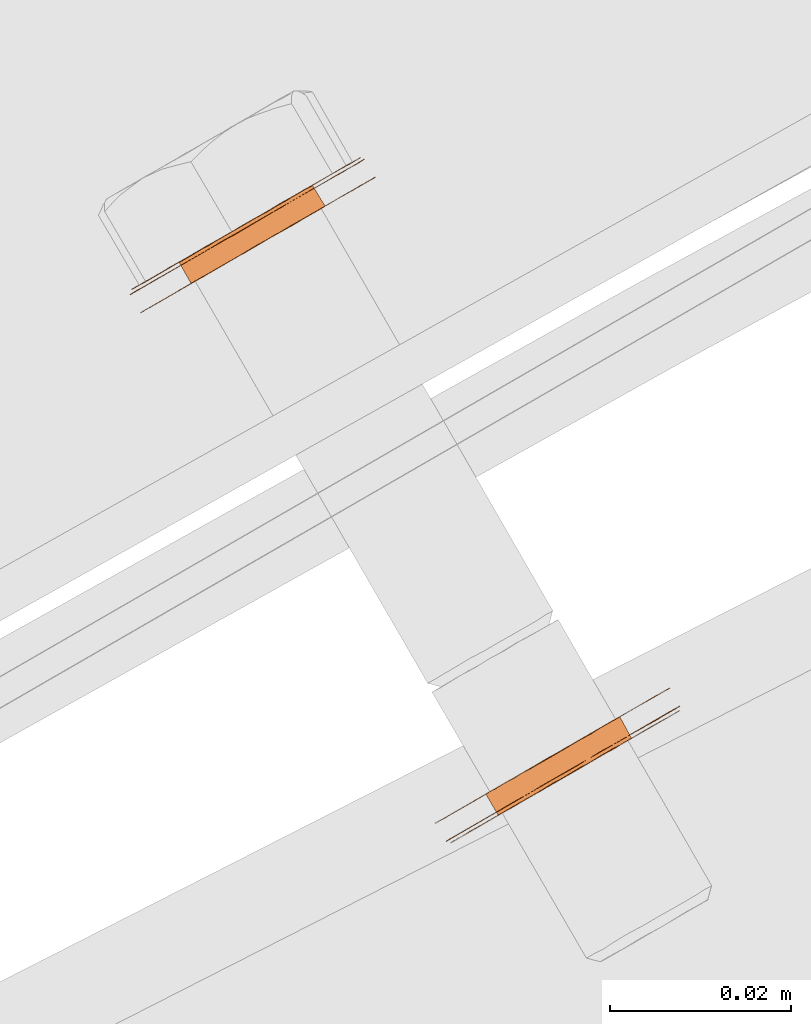
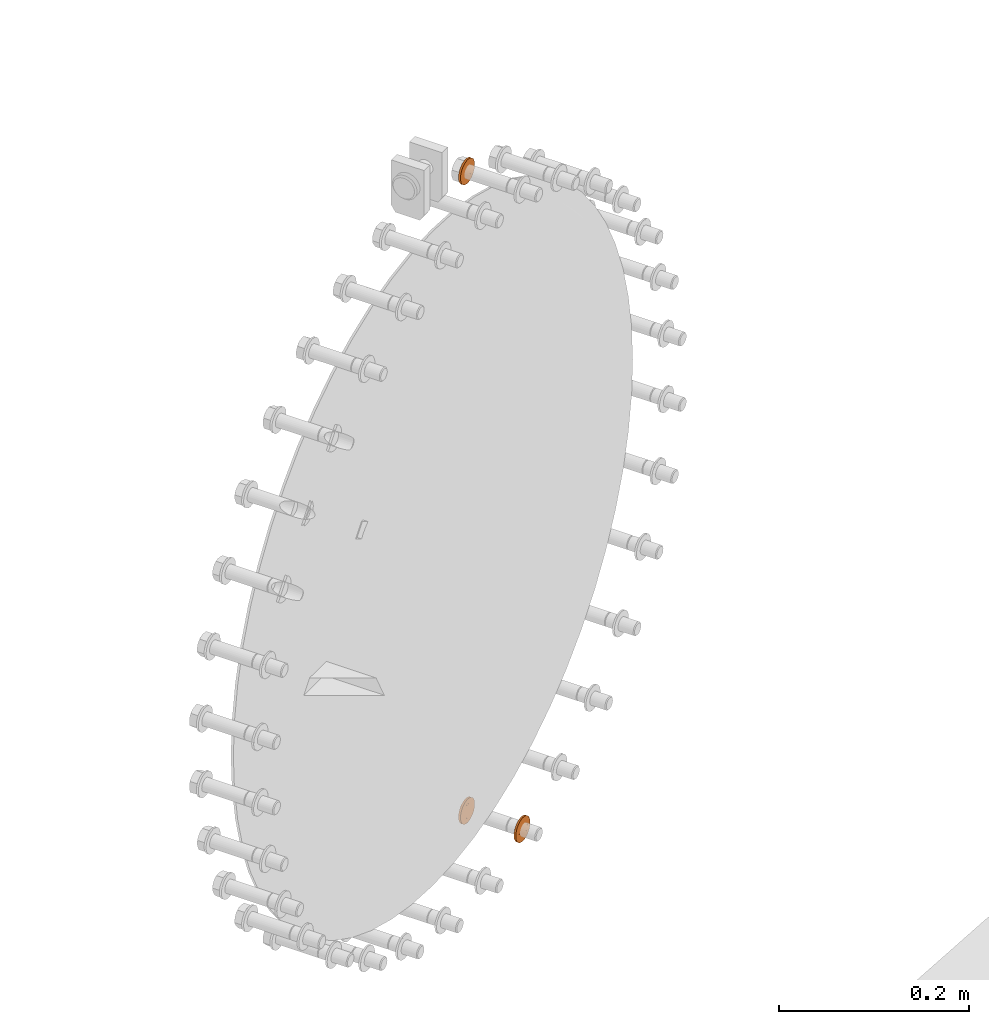
# One storey, part 111 of 126: 3 proxies.
"""IFC2X3 building model written with IfcOpenShell, lengths in millimetres."""

from ifc_helpers import new_model, si_unit, origin, origin_with_axes, place, context, project, spatial, faceted_brep, material, element, save


model = new_model("IFC2X3")

# Units and contexts
context_of_model_1 = context(None, 3, precision=0.1, world=origin())
context_of_model_2 = context(None, 3, precision=0.1, world=origin())
ifc_project = project(units=[si_unit("LENGTHUNIT", "METRE", prefix="MILLI"), si_unit("AREAUNIT", "SQUARE_METRE", prefix="CENTI"), si_unit("VOLUMEUNIT", "CUBIC_METRE", prefix="CENTI"), si_unit("MASSUNIT", "GRAM", prefix="KILO")], contexts=[context_of_model_1, context_of_model_2])

# Site, building, storey
site_placement = place(None, origin_with_axes())
site = spatial("IfcSite", under=ifc_project, at=site_placement, CompositionType="ELEMENT")
building_placement = place(site_placement, origin_with_axes())
building = spatial("IfcBuilding", under=site, at=building_placement, CompositionType="ELEMENT")
storey_placement = place(building_placement, origin_with_axes())
storey = spatial("IfcBuildingStorey", under=building, at=storey_placement, CompositionType="ELEMENT")

# Proxies
ifc_material = material(Name="STAHL")
proxy_1_placement = place(storey_placement, origin_with_axes())
element("IfcBuildingElementProxy", 1, at=proxy_1_placement, inside=storey, material=ifc_material, Name="profile", context=context_of_model_2, shape_type="Brep", body=[
    faceted_brep([(4093.0, 15031.0, 1299.0), (4094.4, 15028.7, 1299.0), (4095.4, 15029.3, 1299.1), (4094.1, 15031.6, 1299.1), (4092.0, 15030.4, 1299.0), (4093.3, 15028.1, 1299.0), (4090.9, 15029.8, 1299.2), (4092.3, 15027.5, 1299.2), (4096.5, 15033.0, 1314.8), (4097.9, 15030.7, 1314.8), (4096.9, 15030.1, 1315.3), (4095.6, 15032.5, 1315.3), (4089.9, 15029.2, 1299.6), (4091.3, 15026.9, 1299.6), (4097.4, 15033.5, 1314.1), (4098.7, 15031.2, 1314.1), (4098.1, 15034.0, 1313.3), (4099.5, 15031.6, 1313.3), (4098.8, 15034.4, 1312.3), (4100.1, 15032.0, 1312.3), (4099.3, 15034.7, 1311.3), (4100.7, 15032.3, 1311.3), (4099.7, 15034.9, 1310.2), (4101.1, 15032.6, 1310.2), (4100.0, 15035.0, 1309.0), (4101.3, 15032.7, 1309.0), (4100.1, 15035.1, 1307.8), (4101.5, 15032.8, 1307.8), (4100.1, 15035.1, 1306.6), (4101.4, 15032.7, 1306.6), (4099.9, 15035.0, 1305.4), (4101.2, 15032.6, 1305.4), (4099.6, 15034.8, 1304.2), (4100.9, 15032.4, 1304.2), (4099.1, 15034.5, 1303.1), (4100.4, 15032.2, 1303.1), (4098.5, 15034.2, 1302.2), (4099.8, 15031.8, 1302.2), (4097.8, 15033.8, 1301.3), (4099.1, 15031.4, 1301.3), (4096.9, 15033.3, 1300.5), (4098.3, 15030.9, 1300.5), (4096.0, 15032.8, 1299.9), (4097.4, 15030.4, 1299.9), (4095.1, 15032.2, 1299.4), (4096.4, 15029.9, 1299.4), (4081.1, 15021.0, 1307.1), (4081.1, 15021.0, 1308.7), (4081.3, 15021.1, 1310.2), (4081.6, 15021.3, 1311.7), (4082.1, 15021.6, 1313.2), (4082.7, 15021.9, 1314.6), (4083.4, 15022.3, 1316.0), (4084.2, 15022.8, 1317.2), (4085.2, 15023.4, 1318.4), (4086.2, 15024.0, 1319.4), (4087.3, 15024.6, 1320.3), (4088.5, 15025.3, 1321.0), (4089.8, 15026.0, 1321.6), (4091.1, 15026.8, 1322.1), (4092.4, 15027.5, 1322.4), (4093.8, 15028.3, 1322.5), (4095.1, 15029.1, 1322.4), (4096.5, 15029.9, 1322.2), (4097.8, 15030.7, 1321.9), (4099.1, 15031.4, 1321.3), (4100.3, 15032.1, 1320.7), (4101.5, 15032.8, 1319.8), (4102.5, 15033.4, 1318.9), (4103.5, 15034.0, 1317.8), (4104.4, 15034.5, 1316.6), (4105.2, 15034.9, 1315.3), (4105.8, 15035.3, 1313.9), (4106.3, 15035.6, 1312.5), (4106.7, 15035.8, 1311.0), (4107.0, 15036.0, 1309.4), (4107.1, 15036.0, 1307.9), (4107.0, 15036.0, 1306.3), (4106.9, 15035.9, 1304.8), (4106.6, 15035.7, 1303.2), (4106.1, 15035.5, 1301.7), (4105.5, 15035.1, 1300.3), (4104.8, 15034.7, 1299.0), (4104.0, 15034.2, 1297.7), (4103.0, 15033.7, 1296.6), (4102.0, 15033.1, 1295.6), (4100.9, 15035.1, 1295.6), (4101.9, 15035.7, 1296.6), (4102.8, 15036.2, 1297.7), (4103.7, 15036.7, 1299.0), (4104.4, 15037.1, 1300.3), (4105.0, 15037.4, 1301.7), (4105.4, 15037.7, 1303.2), (4105.7, 15037.9, 1304.8), (4105.9, 15038.0, 1306.3), (4105.9, 15038.0, 1307.9), (4105.8, 15038.0, 1309.4), (4105.6, 15037.8, 1311.0), (4105.2, 15037.6, 1312.5), (4104.7, 15037.3, 1313.9), (4104.0, 15036.9, 1315.3), (4103.3, 15036.5, 1316.6), (4102.4, 15036.0, 1317.8), (4101.4, 15035.4, 1318.9), (4100.3, 15034.8, 1319.8), (4099.1, 15034.1, 1320.7), (4097.9, 15033.4, 1321.3), (4096.6, 15032.6, 1321.9), (4095.3, 15031.9, 1322.2), (4094.0, 15031.1, 1322.4), (4092.6, 15030.3, 1322.5), (4091.3, 15029.5, 1322.4), (4089.9, 15028.8, 1322.1), (4088.6, 15028.0, 1321.6), (4087.4, 15027.3, 1321.0), (4086.2, 15026.6, 1320.3), (4085.0, 15025.9, 1319.4), (4084.0, 15025.4, 1318.4), (4083.1, 15024.8, 1317.2), (4082.2, 15024.3, 1316.0), (4081.5, 15023.9, 1314.6), (4080.9, 15023.6, 1313.2), (4080.5, 15023.3, 1311.7), (4080.2, 15023.1, 1310.2), (4080.0, 15023.0, 1308.7), (4080.0, 15023.0, 1307.1), (4080.1, 15023.1, 1305.5), (4080.3, 15023.2, 1304.0), (4080.7, 15023.4, 1302.5), (4081.2, 15023.7, 1301.0), (4081.9, 15024.1, 1299.6), (4082.6, 15024.6, 1298.4), (4083.5, 15025.1, 1297.2), (4084.5, 15025.6, 1296.1), (4085.6, 15026.3, 1295.1), (4086.8, 15026.9, 1294.3), (4088.0, 15027.6, 1293.6), (4089.3, 15028.4, 1293.1), (4090.6, 15029.1, 1292.7), (4091.9, 15029.9, 1292.5), (4093.3, 15030.7, 1292.5), (4094.6, 15031.5, 1292.6), (4096.0, 15032.3, 1292.9), (4097.3, 15033.0, 1293.3), (4098.5, 15033.7, 1293.9), (4099.7, 15034.4, 1294.7), (4100.9, 15032.4, 1294.7), (4099.7, 15031.8, 1293.9), (4098.4, 15031.0, 1293.3), (4097.1, 15030.3, 1292.9), (4095.8, 15029.5, 1292.6), (4094.4, 15028.7, 1292.5), (4093.1, 15027.9, 1292.5), (4091.7, 15027.2, 1292.7), (4090.4, 15026.4, 1293.1), (4089.1, 15025.7, 1293.6), (4087.9, 15024.9, 1294.3), (4086.7, 15024.3, 1295.1), (4085.7, 15023.7, 1296.1), (4084.7, 15023.1, 1297.2), (4083.8, 15022.6, 1298.4), (4083.0, 15022.1, 1299.6), (4082.4, 15021.8, 1301.0), (4081.9, 15021.5, 1302.5), (4081.5, 15021.2, 1304.0), (4081.2, 15021.1, 1305.5), (4081.2, 15024.2, 1301.5), (4081.8, 15024.6, 1300.1), (4082.6, 15025.0, 1298.8), (4083.5, 15025.5, 1297.6), (4084.4, 15026.1, 1296.5), (4085.5, 15026.7, 1295.5), (4086.7, 15027.4, 1294.7), (4087.9, 15028.1, 1294.0), (4089.2, 15028.8, 1293.5), (4090.5, 15029.6, 1293.1), (4091.9, 15030.4, 1292.9), (4093.3, 15031.2, 1292.9), (4094.6, 15031.9, 1293.0), (4096.0, 15032.7, 1293.4), (4097.3, 15033.5, 1293.8), (4098.5, 15034.2, 1294.5), (4099.7, 15034.9, 1295.3), (4100.8, 15035.5, 1296.2), (4101.8, 15036.1, 1297.3), (4102.7, 15036.6, 1298.5), (4103.5, 15037.1, 1299.8), (4104.2, 15037.4, 1301.2), (4104.7, 15037.7, 1302.6), (4105.1, 15038.0, 1304.2), (4105.3, 15038.1, 1305.7), (4105.4, 15038.2, 1307.3), (4105.3, 15038.1, 1308.9), (4105.1, 15038.0, 1310.4), (4104.8, 15037.8, 1312.0), (4104.3, 15037.5, 1313.4), (4103.7, 15037.2, 1314.8), (4102.9, 15036.7, 1316.2), (4102.0, 15036.2, 1317.4), (4101.1, 15035.7, 1318.5), (4100.0, 15035.0, 1319.5), (4098.8, 15034.4, 1320.3), (4097.6, 15033.7, 1321.0), (4096.3, 15032.9, 1321.5), (4095.0, 15032.1, 1321.9), (4093.6, 15031.4, 1322.1), (4092.2, 15030.6, 1322.1), (4090.9, 15029.8, 1321.9), (4089.5, 15029.0, 1321.6), (4088.2, 15028.3, 1321.1), (4087.0, 15027.5, 1320.5), (4085.8, 15026.8, 1319.7), (4084.7, 15026.2, 1318.7), (4083.7, 15025.6, 1317.7), (4082.8, 15025.1, 1316.5), (4082.0, 15024.7, 1315.2), (4081.3, 15024.3, 1313.8), (4080.8, 15024.0, 1312.3), (4080.4, 15023.8, 1310.8), (4080.2, 15023.6, 1309.3), (4080.1, 15023.6, 1307.7), (4080.2, 15023.6, 1306.1), (4080.4, 15023.7, 1304.5), (4080.7, 15023.9, 1303.0), (4085.8, 15026.8, 1304.8), (4086.2, 15027.1, 1303.7), (4086.7, 15027.4, 1302.6), (4087.4, 15027.8, 1301.7), (4088.1, 15028.2, 1300.9), (4089.0, 15028.7, 1300.2), (4094.6, 15031.9, 1315.7), (4093.5, 15031.3, 1315.9), (4092.5, 15030.7, 1316.0), (4091.4, 15030.1, 1315.8), (4090.4, 15029.5, 1315.5), (4089.5, 15029.0, 1315.1), (4088.6, 15028.4, 1314.5), (4087.7, 15028.0, 1313.7), (4087.0, 15027.6, 1312.8), (4086.4, 15027.2, 1311.8), (4085.9, 15026.9, 1310.7), (4085.6, 15026.7, 1309.6), (4085.4, 15026.6, 1308.4), (4085.4, 15026.6, 1307.2), (4085.5, 15026.7, 1306.0), (4095.9, 15029.6, 1315.7), (4090.3, 15026.4, 1300.2), (4089.5, 15025.9, 1300.9), (4088.7, 15025.4, 1301.7), (4088.1, 15025.0, 1302.6), (4087.5, 15024.7, 1303.7), (4087.1, 15024.5, 1304.8), (4086.9, 15024.3, 1306.0), (4086.7, 15024.3, 1307.2), (4086.8, 15024.3, 1308.4), (4087.0, 15024.4, 1309.6), (4087.3, 15024.6, 1310.7), (4087.8, 15024.9, 1311.8), (4088.4, 15025.2, 1312.8), (4089.1, 15025.6, 1313.7), (4089.9, 15026.1, 1314.5), (4090.8, 15026.6, 1315.1), (4091.8, 15027.2, 1315.5), (4092.8, 15027.8, 1315.8), (4093.8, 15028.4, 1316.0), (4094.9, 15029.0, 1315.9)], [[[0, 1, 2, 3]], [[4, 5, 1, 0]], [[6, 7, 5, 4]], [[8, 9, 10, 11]], [[12, 13, 7, 6]], [[14, 15, 9, 8]], [[16, 17, 15, 14]], [[18, 19, 17, 16]], [[20, 21, 19, 18]], [[22, 23, 21, 20]], [[24, 25, 23, 22]], [[26, 27, 25, 24]], [[28, 29, 27, 26]], [[30, 31, 29, 28]], [[32, 33, 31, 30]], [[34, 35, 33, 32]], [[36, 37, 35, 34]], [[38, 39, 37, 36]], [[40, 41, 39, 38]], [[42, 43, 41, 40]], [[44, 45, 43, 42]], [[3, 2, 45, 44]], [[46, 47, 48, 49, 50, 51, 52, 53, 54, 55, 56, 57, 58, 59, 60, 61, 62, 63, 64, 65, 66, 67, 68, 69, 70, 71, 72, 73, 74, 75, 76, 77, 78, 79, 80, 81, 82, 83, 84, 85, 86, 87, 88, 89, 90, 91, 92, 93, 94, 95, 96, 97, 98, 99, 100, 101, 102, 103, 104, 105, 106, 107, 108, 109, 110, 111, 112, 113, 114, 115, 116, 117, 118, 119, 120, 121, 122, 123, 124, 125, 126, 127, 128, 129, 130, 131, 132, 133, 134, 135, 136, 137, 138, 139, 140, 141, 142, 143, 144, 145, 86, 85, 146, 147, 148, 149, 150, 151, 152, 153, 154, 155, 156, 157, 158, 159, 160, 161, 162, 163, 164, 165]], [[125, 124, 123, 122, 121, 120, 119, 118, 117, 116, 115, 114, 113, 112, 111, 110, 109, 108, 107, 106, 105, 104, 103, 102, 101, 100, 99, 98, 97, 96, 95, 94, 93, 92, 91, 90, 89, 88, 87, 86, 145, 144, 143, 142, 141, 140, 139, 138, 137, 136, 135, 134, 133, 132, 131, 130, 129, 166, 167, 168, 169, 170, 171, 172, 173, 174, 175, 176, 177, 178, 179, 180, 181, 182, 183, 184, 185, 186, 187, 188, 189, 190, 191, 192, 193, 194, 195, 196, 197, 198, 199, 200, 201, 202, 203, 204, 205, 206, 207, 208, 209, 210, 211, 212, 213, 214, 215, 216, 217, 218, 219, 220, 221, 222, 223, 166, 129, 128, 127, 126]], [[220, 219, 218, 217, 216, 215, 214, 213, 212, 211, 210, 209, 208, 207, 206, 205, 204, 203, 202, 201, 200, 199, 198, 197, 196, 195, 194, 193, 192, 191, 190, 189, 188, 187, 186, 185, 184, 183, 182, 181, 180, 179, 178, 177, 176, 175, 174, 173, 172, 171, 170, 169, 168, 167, 166, 223, 222, 224, 225, 226, 227, 228, 229, 12, 6, 4, 0, 3, 44, 42, 40, 38, 36, 34, 32, 30, 28, 26, 24, 22, 20, 18, 16, 14, 8, 11, 230, 231, 232, 233, 234, 235, 236, 237, 238, 239, 240, 241, 242, 243, 244, 224, 222, 221]], [[230, 11, 10, 245]], [[12, 229, 246, 13]], [[229, 228, 247, 246]], [[228, 227, 248, 247]], [[227, 226, 249, 248]], [[226, 225, 250, 249]], [[225, 224, 251, 250]], [[224, 244, 252, 251]], [[244, 243, 253, 252]], [[243, 242, 254, 253]], [[242, 241, 255, 254]], [[241, 240, 256, 255]], [[240, 239, 257, 256]], [[239, 238, 258, 257]], [[238, 237, 259, 258]], [[237, 236, 260, 259]], [[236, 235, 261, 260]], [[235, 234, 262, 261]], [[234, 233, 263, 262]], [[233, 232, 264, 263]], [[232, 231, 265, 264]], [[231, 230, 245, 265]], [[46, 165, 164, 163, 251, 252, 253, 254, 255, 256, 257, 258, 259, 260, 261, 262, 263, 264, 265, 245, 10, 9, 15, 17, 19, 21, 23, 25, 27, 29, 31, 33, 35, 37, 39, 41, 43, 45, 2, 1, 5, 7, 13, 246, 247, 248, 249, 250, 251, 163, 162, 161, 160, 159, 158, 157, 156, 155, 154, 153, 152, 151, 150, 149, 148, 147, 146, 85, 84, 83, 82, 81, 80, 79, 78, 77, 76, 75, 74, 73, 72, 71, 70, 69, 68, 67, 66, 65, 64, 63, 62, 61, 60, 59, 58, 57, 56, 55, 54, 53, 52, 51, 50, 49, 48, 47]]]),
])
proxy_2_placement = place(storey_placement, origin_with_axes())
element("IfcBuildingElementProxy", 2, at=proxy_2_placement, inside=storey, material=ifc_material, Name="profile", context=context_of_model_2, shape_type="Brep", body=[
    faceted_brep([(4126.5, 14969.1, 492.9), (4125.2, 14971.4, 492.9), (4126.2, 14972.0, 493.0), (4127.6, 14969.7, 493.0), (4129.4, 14970.7, 476.2), (4130.4, 14971.3, 476.5), (4129.0, 14973.6, 476.5), (4128.0, 14973.1, 476.2), (4131.4, 14971.9, 477.0), (4130.0, 14974.2, 477.0), (4132.3, 14972.4, 477.6), (4130.9, 14974.7, 477.6), (4133.1, 14972.8, 478.4), (4131.7, 14975.2, 478.4), (4133.8, 14973.2, 479.3), (4132.4, 14975.6, 479.3), (4134.3, 14973.6, 480.3), (4133.0, 14975.9, 480.3), (4134.8, 14973.8, 481.4), (4133.4, 14976.2, 481.4), (4135.1, 14974.0, 482.6), (4133.8, 14976.4, 482.6), (4135.3, 14974.1, 483.8), (4133.9, 14976.5, 483.8), (4135.3, 14974.1, 485.0), (4134.0, 14976.5, 485.0), (4135.2, 14974.1, 486.2), (4133.8, 14976.4, 486.2), (4134.9, 14973.9, 487.3), (4133.5, 14976.2, 487.3), (4134.5, 14973.7, 488.5), (4133.1, 14976.0, 488.5), (4133.9, 14973.3, 489.5), (4132.6, 14975.7, 489.5), (4133.2, 14973.0, 490.4), (4131.9, 14975.3, 490.4), (4132.5, 14972.5, 491.2), (4131.1, 14974.8, 491.2), (4131.6, 14972.0, 491.9), (4130.2, 14974.3, 491.9), (4130.6, 14971.4, 492.4), (4129.3, 14973.8, 492.4), (4129.6, 14970.9, 492.8), (4128.3, 14973.2, 492.8), (4128.6, 14970.3, 493.0), (4127.3, 14972.6, 493.0), (4114.8, 14962.7, 484.7), (4114.8, 14962.8, 486.3), (4115.1, 14962.9, 487.8), (4115.4, 14963.1, 489.3), (4116.0, 14963.4, 490.8), (4116.6, 14963.8, 492.2), (4117.3, 14964.2, 493.5), (4118.2, 14964.7, 494.7), (4119.2, 14965.3, 495.8), (4120.3, 14965.9, 496.8), (4121.4, 14966.6, 497.6), (4122.6, 14967.3, 498.3), (4123.9, 14968.0, 498.8), (4125.2, 14968.8, 499.2), (4126.6, 14969.6, 499.5), (4127.9, 14970.3, 499.5), (4129.3, 14971.1, 499.4), (4130.6, 14971.9, 499.1), (4131.9, 14972.7, 498.7), (4133.2, 14973.4, 498.1), (4134.4, 14974.1, 497.4), (4135.5, 14974.7, 496.5), (4136.6, 14975.3, 495.5), (4137.5, 14975.9, 494.4), (4137.2, 14978.4, 493.2), (4136.4, 14977.9, 494.4), (4135.4, 14977.3, 495.5), (4134.4, 14976.7, 496.5), (4133.2, 14976.1, 497.4), (4132.0, 14975.4, 498.1), (4130.8, 14974.6, 498.7), (4129.5, 14973.9, 499.1), (4128.1, 14973.1, 499.4), (4126.8, 14972.3, 499.5), (4125.4, 14971.5, 499.5), (4124.1, 14970.8, 499.2), (4122.7, 14970.0, 498.8), (4121.5, 14969.3, 498.3), (4120.3, 14968.6, 497.6), (4119.1, 14967.9, 496.8), (4118.0, 14967.3, 495.8), (4117.1, 14966.7, 494.7), (4116.2, 14966.2, 493.5), (4115.4, 14965.8, 492.2), (4114.8, 14965.4, 490.8), (4114.3, 14965.1, 489.3), (4113.9, 14964.9, 487.8), (4113.7, 14964.8, 486.3), (4113.6, 14964.7, 484.7), (4113.7, 14964.8, 483.1), (4113.9, 14964.9, 481.6), (4114.2, 14965.1, 480.1), (4114.7, 14965.3, 478.6), (4115.3, 14965.7, 477.2), (4116.0, 14966.1, 475.9), (4116.8, 14966.6, 474.6), (4117.8, 14967.1, 473.5), (4118.8, 14967.7, 472.5), (4120.0, 14968.4, 471.6), (4121.2, 14969.1, 470.9), (4122.4, 14969.8, 470.3), (4123.7, 14970.6, 469.9), (4125.1, 14971.4, 469.6), (4126.4, 14972.1, 469.5), (4127.8, 14972.9, 469.6), (4129.1, 14973.7, 469.8), (4130.5, 14974.5, 470.2), (4131.7, 14975.2, 470.7), (4132.9, 14975.9, 471.4), (4134.1, 14976.6, 472.3), (4135.2, 14977.2, 473.2), (4136.1, 14977.7, 474.3), (4137.0, 14978.2, 475.5), (4137.8, 14978.7, 476.8), (4138.4, 14979.0, 478.2), (4138.9, 14979.3, 479.7), (4139.3, 14979.5, 481.2), (4139.5, 14979.7, 482.8), (4139.6, 14979.7, 484.3), (4139.5, 14979.7, 485.9), (4139.3, 14979.6, 487.4), (4139.0, 14979.4, 489.0), (4138.5, 14979.1, 490.4), (4137.9, 14978.8, 491.8), (4138.4, 14976.4, 493.2), (4139.1, 14976.8, 491.8), (4139.7, 14977.1, 490.4), (4140.2, 14977.4, 489.0), (4140.5, 14977.6, 487.4), (4140.7, 14977.7, 485.9), (4140.7, 14977.7, 484.3), (4140.6, 14977.7, 482.8), (4140.4, 14977.6, 481.2), (4140.1, 14977.3, 479.7), (4139.5, 14977.1, 478.2), (4138.9, 14976.7, 476.8), (4138.2, 14976.2, 475.5), (4137.3, 14975.7, 474.3), (4136.3, 14975.2, 473.2), (4135.2, 14974.6, 472.3), (4134.1, 14973.9, 471.4), (4132.9, 14973.2, 470.7), (4131.6, 14972.5, 470.2), (4130.3, 14971.7, 469.8), (4128.9, 14970.9, 469.6), (4127.6, 14970.1, 469.5), (4126.2, 14969.4, 469.6), (4124.9, 14968.6, 469.9), (4123.6, 14967.8, 470.3), (4122.3, 14967.1, 470.9), (4121.1, 14966.4, 471.6), (4120.0, 14965.8, 472.5), (4118.9, 14965.1, 473.5), (4118.0, 14964.6, 474.6), (4117.1, 14964.1, 475.9), (4116.4, 14963.7, 477.2), (4115.8, 14963.3, 478.6), (4115.3, 14963.1, 480.1), (4115.0, 14962.9, 481.6), (4114.8, 14962.8, 483.1), (4115.3, 14962.6, 484.0), (4115.3, 14962.6, 485.6), (4115.5, 14962.7, 487.2), (4115.8, 14962.9, 488.7), (4116.3, 14963.2, 490.2), (4116.9, 14963.5, 491.6), (4117.6, 14963.9, 493.0), (4118.5, 14964.4, 494.2), (4119.4, 14965.0, 495.3), (4120.5, 14965.6, 496.3), (4121.7, 14966.3, 497.2), (4122.9, 14967.0, 497.9), (4124.2, 14967.7, 498.4), (4125.5, 14968.5, 498.8), (4126.8, 14969.3, 499.1), (4128.2, 14970.0, 499.1), (4129.6, 14970.8, 499.0), (4130.9, 14971.6, 498.7), (4132.2, 14972.4, 498.3), (4133.5, 14973.1, 497.6), (4134.7, 14973.8, 496.9), (4135.8, 14974.4, 496.0), (4136.8, 14975.0, 494.9), (4137.8, 14975.6, 493.7), (4138.6, 14976.0, 492.5), (4139.2, 14976.4, 491.1), (4139.8, 14976.7, 489.6), (4140.2, 14977.0, 488.1), (4140.5, 14977.1, 486.6), (4140.6, 14977.2, 485.0), (4140.6, 14977.2, 483.4), (4140.4, 14977.1, 481.9), (4140.1, 14976.9, 480.3), (4139.6, 14976.6, 478.8), (4139.0, 14976.3, 477.4), (4138.3, 14975.9, 476.1), (4137.4, 14975.4, 474.8), (4136.5, 14974.8, 473.7), (4135.4, 14974.2, 472.7), (4134.2, 14973.5, 471.9), (4133.0, 14972.8, 471.1), (4131.7, 14972.1, 470.6), (4130.4, 14971.3, 470.2), (4129.1, 14970.5, 470.0), (4127.7, 14969.7, 469.9), (4126.3, 14969.0, 470.0), (4125.0, 14968.2, 470.3), (4123.7, 14967.4, 470.8), (4122.4, 14966.7, 471.4), (4121.2, 14966.0, 472.2), (4120.1, 14965.4, 473.1), (4119.1, 14964.8, 474.1), (4118.1, 14964.2, 475.3), (4117.3, 14963.8, 476.6), (4116.7, 14963.4, 477.9), (4116.1, 14963.1, 479.4), (4115.7, 14962.8, 480.9), (4115.4, 14962.7, 482.4), (4121.6, 14966.2, 488.7), (4122.1, 14966.5, 489.7), (4122.8, 14966.9, 490.6), (4123.6, 14967.4, 491.4), (4124.5, 14967.9, 492.0), (4125.5, 14968.5, 492.5), (4128.3, 14970.1, 476.0), (4127.3, 14969.5, 476.0), (4126.3, 14968.9, 476.2), (4125.3, 14968.3, 476.6), (4124.3, 14967.8, 477.1), (4123.4, 14967.3, 477.8), (4122.7, 14966.8, 478.6), (4122.0, 14966.4, 479.5), (4121.4, 14966.1, 480.6), (4121.0, 14965.9, 481.7), (4120.7, 14965.7, 482.9), (4120.6, 14965.6, 484.1), (4120.6, 14965.7, 485.3), (4120.8, 14965.8, 486.5), (4121.1, 14965.9, 487.6), (4124.9, 14971.3, 476.2), (4123.9, 14970.7, 476.6), (4125.9, 14971.9, 476.0), (4124.2, 14970.8, 492.5), (4127.0, 14972.5, 476.0), (4123.2, 14970.3, 492.0), (4122.3, 14969.7, 491.4), (4121.5, 14969.3, 490.6), (4120.8, 14968.9, 489.7), (4120.2, 14968.5, 488.7), (4119.7, 14968.3, 487.6), (4119.4, 14968.1, 486.5), (4119.3, 14968.0, 485.3), (4119.2, 14968.0, 484.1), (4119.4, 14968.1, 482.9), (4119.7, 14968.2, 481.7), (4120.1, 14968.5, 480.6), (4120.6, 14968.8, 479.5), (4121.3, 14969.2, 478.6), (4122.1, 14969.6, 477.8), (4123.0, 14970.1, 477.1)], [[[0, 1, 2, 3]], [[4, 5, 6, 7]], [[5, 8, 9, 6]], [[8, 10, 11, 9]], [[10, 12, 13, 11]], [[12, 14, 15, 13]], [[14, 16, 17, 15]], [[16, 18, 19, 17]], [[18, 20, 21, 19]], [[20, 22, 23, 21]], [[22, 24, 25, 23]], [[24, 26, 27, 25]], [[26, 28, 29, 27]], [[28, 30, 31, 29]], [[30, 32, 33, 31]], [[32, 34, 35, 33]], [[34, 36, 37, 35]], [[36, 38, 39, 37]], [[38, 40, 41, 39]], [[40, 42, 43, 41]], [[42, 44, 45, 43]], [[44, 3, 2, 45]], [[46, 47, 48, 49, 50, 51, 52, 53, 54, 55, 56, 57, 58, 59, 60, 61, 62, 63, 64, 65, 66, 67, 68, 69, 70, 71, 72, 73, 74, 75, 76, 77, 78, 79, 80, 81, 82, 83, 84, 85, 86, 87, 88, 89, 90, 91, 92, 93, 94, 95, 96, 97, 98, 99, 100, 101, 102, 103, 104, 105, 106, 107, 108, 109, 110, 111, 112, 113, 114, 115, 116, 117, 118, 119, 120, 121, 122, 123, 124, 125, 126, 127, 128, 129, 70, 69, 130, 131, 132, 133, 134, 135, 136, 137, 138, 139, 140, 141, 142, 143, 144, 145, 146, 147, 148, 149, 150, 151, 152, 153, 154, 155, 156, 157, 158, 159, 160, 161, 162, 163, 164, 165]], [[166, 167, 168, 169, 170, 171, 51, 50, 49, 48, 47, 46, 165, 164, 163, 162, 161, 160, 159, 158, 157, 156, 155, 154, 153, 152, 151, 150, 149, 148, 147, 146, 145, 144, 143, 142, 141, 140, 139, 138, 137, 136, 135, 134, 133, 132, 131, 130, 69, 68, 67, 66, 65, 64, 63, 62, 61, 60, 59, 58, 57, 56, 55, 54, 53, 52, 51, 171, 172, 173, 174, 175, 176, 177, 178, 179, 180, 181, 182, 183, 184, 185, 186, 187, 188, 189, 190, 191, 192, 193, 194, 195, 196, 197, 198, 199, 200, 201, 202, 203, 204, 205, 206, 207, 208, 209, 210, 211, 212, 213, 214, 215, 216, 217, 218, 219, 220, 221, 222, 223]], [[166, 223, 222, 221, 220, 219, 218, 217, 216, 215, 214, 213, 212, 211, 210, 209, 208, 207, 206, 205, 204, 203, 202, 201, 200, 199, 198, 197, 196, 195, 194, 193, 192, 191, 190, 189, 188, 187, 186, 185, 184, 183, 182, 181, 180, 179, 178, 177, 176, 175, 174, 173, 172, 171, 170, 224, 225, 226, 227, 228, 229, 0, 3, 44, 42, 40, 38, 36, 34, 32, 30, 28, 26, 24, 22, 20, 18, 16, 14, 12, 10, 8, 5, 4, 230, 231, 232, 233, 234, 235, 236, 237, 238, 239, 240, 241, 242, 243, 244, 224, 170, 169, 168, 167]], [[232, 245, 246, 233]], [[231, 247, 245, 232]], [[0, 229, 248, 1]], [[230, 249, 247, 231]], [[4, 7, 249, 230]], [[228, 250, 248, 229]], [[227, 251, 250, 228]], [[226, 252, 251, 227]], [[225, 253, 252, 226]], [[224, 254, 253, 225]], [[244, 255, 254, 224]], [[243, 256, 255, 244]], [[242, 257, 256, 243]], [[241, 258, 257, 242]], [[240, 259, 258, 241]], [[239, 260, 259, 240]], [[238, 261, 260, 239]], [[237, 262, 261, 238]], [[236, 263, 262, 237]], [[235, 264, 263, 236]], [[234, 265, 264, 235]], [[233, 246, 265, 234]], [[94, 93, 92, 91, 90, 89, 88, 87, 253, 254, 255, 256, 257, 258, 259, 260, 261, 262, 263, 264, 265, 246, 245, 247, 249, 7, 6, 9, 11, 13, 15, 17, 19, 21, 23, 25, 27, 29, 31, 33, 35, 37, 39, 41, 43, 45, 2, 1, 248, 250, 251, 252, 253, 87, 86, 85, 84, 83, 82, 81, 80, 79, 78, 77, 76, 75, 74, 73, 72, 71, 70, 129, 128, 127, 126, 125, 124, 123, 122, 121, 120, 119, 118, 117, 116, 115, 114, 113, 112, 111, 110, 109, 108, 107, 106, 105, 104, 103, 102, 101, 100, 99, 98, 97, 96, 95]]]),
])
proxy_3_placement = place(storey_placement, origin_with_axes())
element("IfcBuildingElementProxy", 3, at=proxy_3_placement, inside=storey, material=ifc_material, Name="profile", context=context_of_model_2, shape_type="Brep", body=[
    faceted_brep([(4091.3, 15030.0, 492.9), (4092.7, 15027.7, 492.9), (4091.7, 15027.1, 492.5), (4090.3, 15029.4, 492.5), (4094.2, 15031.7, 476.2), (4093.1, 15031.1, 476.0), (4094.5, 15028.8, 476.0), (4095.5, 15029.4, 476.2), (4092.1, 15030.5, 476.0), (4093.4, 15028.1, 476.0), (4091.1, 15029.9, 476.2), (4092.4, 15027.5, 476.2), (4090.1, 15029.3, 476.6), (4091.4, 15027.0, 476.6), (4089.1, 15028.8, 477.1), (4090.5, 15026.4, 477.1), (4088.2, 15028.3, 477.8), (4089.6, 15025.9, 477.8), (4087.5, 15027.8, 478.6), (4088.8, 15025.5, 478.6), (4086.8, 15027.4, 479.5), (4088.1, 15025.1, 479.5), (4086.2, 15027.1, 480.6), (4087.6, 15024.8, 480.6), (4085.8, 15026.9, 481.7), (4087.2, 15024.5, 481.7), (4085.5, 15026.7, 482.9), (4086.9, 15024.4, 482.9), (4085.4, 15026.6, 484.1), (4086.7, 15024.3, 484.1), (4085.4, 15026.6, 485.3), (4086.8, 15024.3, 485.3), (4085.6, 15026.7, 486.5), (4086.9, 15024.4, 486.5), (4085.9, 15026.9, 487.6), (4087.2, 15024.6, 487.6), (4086.4, 15027.2, 488.7), (4087.7, 15024.8, 488.7), (4086.9, 15027.5, 489.7), (4088.3, 15025.2, 489.7), (4087.6, 15027.9, 490.6), (4089.0, 15025.6, 490.6), (4088.4, 15028.4, 491.4), (4089.8, 15026.0, 491.4), (4089.3, 15028.9, 492.0), (4090.7, 15026.6, 492.0), (4081.1, 15021.0, 484.7), (4081.2, 15021.1, 486.3), (4081.4, 15021.2, 487.8), (4081.8, 15021.4, 489.3), (4080.6, 15023.4, 489.3), (4080.3, 15023.2, 487.8), (4080.0, 15023.1, 486.3), (4080.0, 15023.0, 484.7), (4080.0, 15023.0, 483.1), (4080.2, 15023.2, 481.6), (4080.5, 15023.4, 480.1), (4081.0, 15023.6, 478.6), (4081.6, 15024.0, 477.2), (4082.3, 15024.4, 475.9), (4083.2, 15024.9, 474.6), (4084.1, 15025.4, 473.5), (4085.2, 15026.0, 472.5), (4086.3, 15026.7, 471.6), (4087.5, 15027.4, 470.9), (4088.8, 15028.1, 470.3), (4090.1, 15028.9, 469.9), (4091.4, 15029.6, 469.6), (4092.8, 15030.4, 469.5), (4094.1, 15031.2, 469.6), (4095.5, 15032.0, 469.8), (4096.8, 15032.7, 470.2), (4098.1, 15033.5, 470.7), (4099.3, 15034.2, 471.4), (4100.4, 15034.8, 472.3), (4101.5, 15035.5, 473.2), (4102.5, 15036.0, 474.3), (4103.4, 15036.5, 475.5), (4104.1, 15037.0, 476.8), (4104.7, 15037.3, 478.2), (4105.3, 15037.6, 479.7), (4105.6, 15037.8, 481.2), (4105.8, 15038.0, 482.8), (4105.9, 15038.0, 484.3), (4105.9, 15038.0, 485.9), (4105.7, 15037.9, 487.4), (4105.4, 15037.7, 489.0), (4104.9, 15037.4, 490.4), (4104.3, 15037.1, 491.8), (4103.6, 15036.6, 493.2), (4102.7, 15036.2, 494.4), (4101.8, 15035.6, 495.5), (4100.7, 15035.0, 496.5), (4099.6, 15034.3, 497.4), (4098.4, 15033.7, 498.1), (4097.1, 15032.9, 498.7), (4095.8, 15032.2, 499.1), (4094.5, 15031.4, 499.4), (4093.1, 15030.6, 499.5), (4091.8, 15029.8, 499.5), (4090.4, 15029.1, 499.2), (4089.1, 15028.3, 498.8), (4087.8, 15027.6, 498.3), (4086.6, 15026.9, 497.6), (4085.5, 15026.2, 496.8), (4084.4, 15025.6, 495.8), (4083.4, 15025.0, 494.7), (4082.5, 15024.5, 493.5), (4081.8, 15024.1, 492.2), (4081.2, 15023.7, 490.8), (4082.3, 15021.7, 490.8), (4082.9, 15022.1, 492.2), (4083.7, 15022.5, 493.5), (4084.6, 15023.0, 494.7), (4085.5, 15023.6, 495.8), (4086.6, 15024.2, 496.8), (4087.8, 15024.9, 497.6), (4089.0, 15025.6, 498.3), (4090.2, 15026.3, 498.8), (4091.6, 15027.1, 499.2), (4092.9, 15027.8, 499.5), (4094.3, 15028.6, 499.5), (4095.6, 15029.4, 499.4), (4097.0, 15030.2, 499.1), (4098.3, 15030.9, 498.7), (4099.5, 15031.7, 498.1), (4100.7, 15032.4, 497.4), (4101.9, 15033.0, 496.5), (4102.9, 15033.6, 495.5), (4103.9, 15034.2, 494.4), (4104.7, 15034.6, 493.2), (4105.4, 15035.1, 491.8), (4106.0, 15035.4, 490.4), (4106.5, 15035.7, 489.0), (4106.8, 15035.9, 487.4), (4107.0, 15036.0, 485.9), (4107.1, 15036.0, 484.3), (4107.0, 15036.0, 482.8), (4106.8, 15035.8, 481.2), (4106.4, 15035.6, 479.7), (4105.9, 15035.3, 478.2), (4105.3, 15035.0, 476.8), (4104.5, 15034.5, 475.5), (4103.6, 15034.0, 474.3), (4102.7, 15033.5, 473.2), (4101.6, 15032.9, 472.3), (4100.4, 15032.2, 471.4), (4099.2, 15031.5, 470.7), (4098.0, 15030.7, 470.2), (4096.6, 15030.0, 469.8), (4095.3, 15029.2, 469.6), (4093.9, 15028.4, 469.5), (4092.6, 15027.6, 469.6), (4091.2, 15026.9, 469.9), (4089.9, 15026.1, 470.3), (4088.7, 15025.4, 470.9), (4087.5, 15024.7, 471.6), (4086.3, 15024.0, 472.5), (4085.3, 15023.4, 473.5), (4084.3, 15022.9, 474.6), (4083.5, 15022.4, 475.9), (4082.8, 15022.0, 477.2), (4082.2, 15021.6, 478.6), (4081.7, 15021.4, 480.1), (4081.4, 15021.2, 481.6), (4081.2, 15021.1, 483.1), (4100.6, 15035.4, 496.0), (4099.5, 15034.8, 496.9), (4098.3, 15034.1, 497.6), (4097.0, 15033.3, 498.3), (4095.7, 15032.6, 498.7), (4094.4, 15031.8, 499.0), (4093.0, 15031.0, 499.1), (4091.6, 15030.2, 499.1), (4090.3, 15029.4, 498.8), (4089.0, 15028.7, 498.4), (4087.7, 15027.9, 497.9), (4086.5, 15027.2, 497.2), (4085.3, 15026.6, 496.3), (4084.2, 15026.0, 495.3), (4083.3, 15025.4, 494.2), (4082.4, 15024.9, 493.0), (4081.7, 15024.5, 491.6), (4081.1, 15024.1, 490.2), (4080.6, 15023.9, 488.7), (4080.3, 15023.7, 487.2), (4080.1, 15023.6, 485.6), (4080.1, 15023.6, 484.0), (4080.2, 15023.6, 482.4), (4080.5, 15023.8, 480.9), (4080.9, 15024.0, 479.4), (4081.5, 15024.3, 477.9), (4082.1, 15024.7, 476.6), (4082.9, 15025.2, 475.3), (4083.9, 15025.7, 474.1), (4084.9, 15026.3, 473.1), (4086.0, 15027.0, 472.2), (4087.2, 15027.7, 471.4), (4088.5, 15028.4, 470.8), (4089.8, 15029.1, 470.3), (4091.1, 15029.9, 470.0), (4092.5, 15030.7, 469.9), (4093.9, 15031.5, 470.0), (4095.2, 15032.3, 470.2), (4096.5, 15033.1, 470.6), (4097.8, 15033.8, 471.1), (4099.0, 15034.5, 471.9), (4100.2, 15035.2, 472.7), (4101.3, 15035.8, 473.7), (4102.2, 15036.3, 474.8), (4103.1, 15036.8, 476.1), (4103.8, 15037.2, 477.4), (4104.4, 15037.6, 478.8), (4104.9, 15037.9, 480.3), (4105.2, 15038.0, 481.9), (4105.4, 15038.1, 483.4), (4105.4, 15038.2, 485.0), (4105.3, 15038.1, 486.6), (4105.0, 15037.9, 488.1), (4104.6, 15037.7, 489.6), (4104.0, 15037.4, 491.1), (4103.4, 15037.0, 492.5), (4102.6, 15036.5, 493.7), (4101.6, 15036.0, 494.9), (4097.3, 15033.5, 491.2), (4096.4, 15033.0, 491.9), (4095.4, 15032.4, 492.4), (4094.4, 15031.8, 492.8), (4093.4, 15031.2, 493.0), (4092.4, 15030.6, 493.0), (4095.2, 15032.3, 476.5), (4096.2, 15032.8, 477.0), (4097.1, 15033.3, 477.6), (4097.9, 15033.8, 478.4), (4098.6, 15034.2, 479.3), (4099.1, 15034.6, 480.3), (4099.6, 15034.8, 481.4), (4099.9, 15035.0, 482.6), (4100.1, 15035.1, 483.8), (4100.1, 15035.1, 485.0), (4100.0, 15035.0, 486.2), (4099.7, 15034.9, 487.3), (4099.3, 15034.6, 488.5), (4098.7, 15034.3, 489.5), (4098.0, 15033.9, 490.4), (4098.4, 15031.0, 477.6), (4099.2, 15031.5, 478.4), (4097.5, 15030.5, 477.0), (4096.5, 15029.9, 476.5), (4093.7, 15028.3, 493.0), (4094.8, 15028.9, 493.0), (4095.8, 15029.5, 492.8), (4096.8, 15030.1, 492.4), (4097.7, 15030.6, 491.9), (4098.6, 15031.1, 491.2), (4099.4, 15031.6, 490.4), (4100.1, 15032.0, 489.5), (4100.6, 15032.3, 488.5), (4101.0, 15032.5, 487.3), (4101.3, 15032.7, 486.2), (4101.5, 15032.8, 485.0), (4101.4, 15032.8, 483.8), (4101.3, 15032.7, 482.6), (4100.9, 15032.5, 481.4), (4100.5, 15032.2, 480.3), (4099.9, 15031.9, 479.3)], [[[0, 1, 2, 3]], [[4, 5, 6, 7]], [[5, 8, 9, 6]], [[8, 10, 11, 9]], [[10, 12, 13, 11]], [[12, 14, 15, 13]], [[14, 16, 17, 15]], [[16, 18, 19, 17]], [[18, 20, 21, 19]], [[20, 22, 23, 21]], [[22, 24, 25, 23]], [[24, 26, 27, 25]], [[26, 28, 29, 27]], [[28, 30, 31, 29]], [[30, 32, 33, 31]], [[32, 34, 35, 33]], [[34, 36, 37, 35]], [[36, 38, 39, 37]], [[38, 40, 41, 39]], [[40, 42, 43, 41]], [[42, 44, 45, 43]], [[44, 3, 2, 45]], [[46, 47, 48, 49, 50, 51, 52, 53, 54, 55, 56, 57, 58, 59, 60, 61, 62, 63, 64, 65, 66, 67, 68, 69, 70, 71, 72, 73, 74, 75, 76, 77, 78, 79, 80, 81, 82, 83, 84, 85, 86, 87, 88, 89, 90, 91, 92, 93, 94, 95, 96, 97, 98, 99, 100, 101, 102, 103, 104, 105, 106, 107, 108, 109, 50, 49, 110, 111, 112, 113, 114, 115, 116, 117, 118, 119, 120, 121, 122, 123, 124, 125, 126, 127, 128, 129, 130, 131, 132, 133, 134, 135, 136, 137, 138, 139, 140, 141, 142, 143, 144, 145, 146, 147, 148, 149, 150, 151, 152, 153, 154, 155, 156, 157, 158, 159, 160, 161, 162, 163, 164, 165]], [[53, 52, 51, 50, 109, 108, 107, 106, 105, 104, 103, 102, 101, 100, 99, 98, 97, 96, 95, 94, 93, 92, 166, 167, 168, 169, 170, 171, 172, 173, 174, 175, 176, 177, 178, 179, 180, 181, 182, 183, 184, 185, 186, 187, 188, 189, 190, 191, 192, 193, 194, 195, 196, 197, 198, 199, 200, 201, 202, 203, 204, 205, 206, 207, 208, 209, 210, 211, 212, 213, 214, 215, 216, 217, 218, 219, 220, 221, 222, 223, 166, 92, 91, 90, 89, 88, 87, 86, 85, 84, 83, 82, 81, 80, 79, 78, 77, 76, 75, 74, 73, 72, 71, 70, 69, 68, 67, 66, 65, 64, 63, 62, 61, 60, 59, 58, 57, 56, 55, 54]], [[187, 186, 185, 184, 183, 182, 181, 180, 179, 178, 177, 176, 175, 174, 173, 172, 171, 170, 169, 168, 167, 166, 223, 224, 225, 226, 227, 228, 229, 0, 3, 44, 42, 40, 38, 36, 34, 32, 30, 28, 26, 24, 22, 20, 18, 16, 14, 12, 10, 8, 5, 4, 230, 231, 232, 233, 234, 235, 236, 237, 238, 239, 240, 241, 242, 243, 244, 224, 223, 222, 221, 220, 219, 218, 217, 216, 215, 214, 213, 212, 211, 210, 209, 208, 207, 206, 205, 204, 203, 202, 201, 200, 199, 198, 197, 196, 195, 194, 193, 192, 191, 190, 189, 188]], [[232, 245, 246, 233]], [[231, 247, 245, 232]], [[230, 248, 247, 231]], [[229, 249, 1, 0]], [[4, 7, 248, 230]], [[228, 250, 249, 229]], [[227, 251, 250, 228]], [[226, 252, 251, 227]], [[225, 253, 252, 226]], [[224, 254, 253, 225]], [[244, 255, 254, 224]], [[243, 256, 255, 244]], [[242, 257, 256, 243]], [[241, 258, 257, 242]], [[240, 259, 258, 241]], [[239, 260, 259, 240]], [[238, 261, 260, 239]], [[237, 262, 261, 238]], [[236, 263, 262, 237]], [[235, 264, 263, 236]], [[234, 265, 264, 235]], [[233, 246, 265, 234]], [[46, 165, 164, 163, 162, 161, 160, 159, 158, 157, 156, 155, 154, 153, 152, 151, 150, 149, 148, 147, 146, 145, 144, 143, 142, 141, 140, 139, 138, 137, 136, 135, 134, 133, 132, 131, 130, 129, 128, 127, 126, 125, 253, 254, 255, 256, 257, 258, 259, 260, 261, 262, 263, 264, 265, 246, 245, 247, 248, 7, 6, 9, 11, 13, 15, 17, 19, 21, 23, 25, 27, 29, 31, 33, 35, 37, 39, 41, 43, 45, 2, 1, 249, 250, 251, 252, 253, 125, 124, 123, 122, 121, 120, 119, 118, 117, 116, 115, 114, 113, 112, 111, 110, 49, 48, 47]]]),
])

save(model, "model.ifc")
